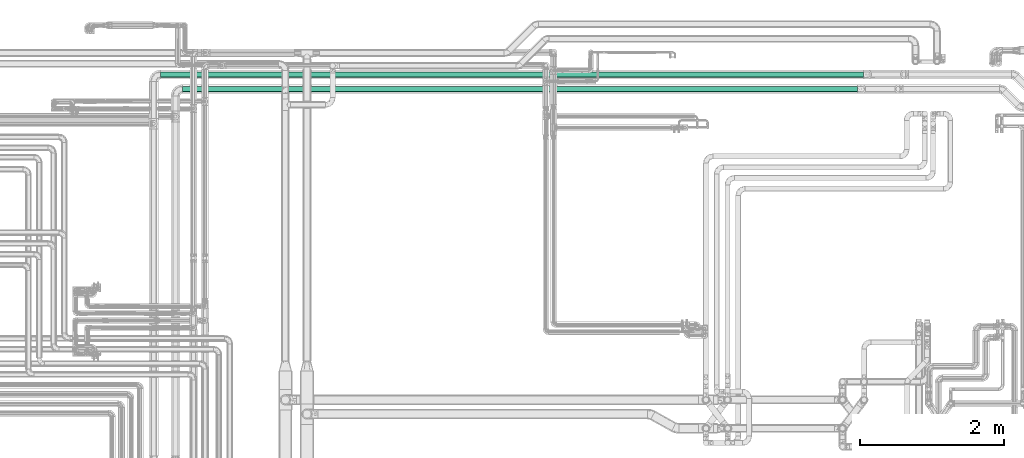
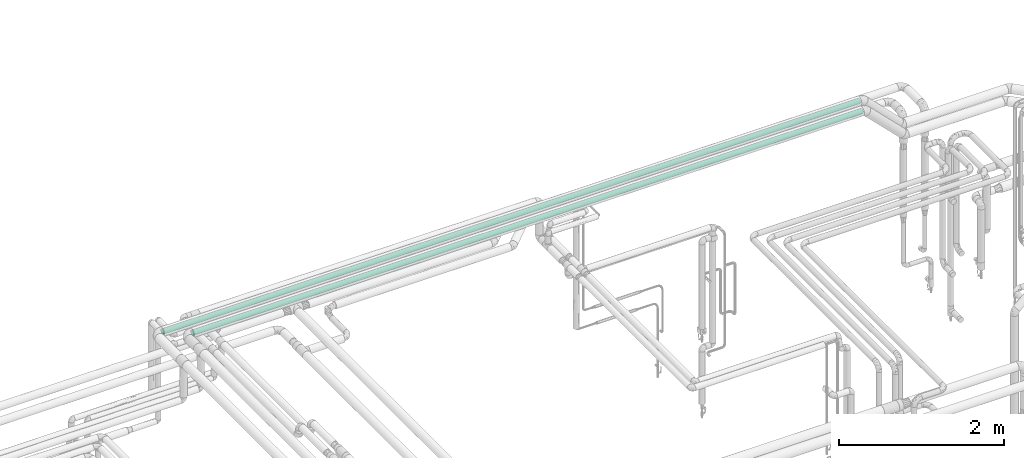
# One storey, part 537 of 827: 2 flow segments.
"""IFC2X3 building model written with IfcOpenShell, lengths in millimetres."""

from ifc_helpers import new_model, entity, si_unit, converted_unit, derived_unit, direction, frame, origin, origin_2d_with_axis, place, context, subcontext, project, spatial, circle, extrude, type_object, element, save


model = new_model("IFC2X3")

# Units and contexts
model_context = context("Model", 3, precision=0.01, world=origin(), true_north=direction((6.12303176911189e-17, 1.0)))
body_context = subcontext(model_context, "Body", "Model", "MODEL_VIEW")
ifc_project = project(units=[si_unit("LENGTHUNIT", "METRE", prefix="MILLI"), si_unit("AREAUNIT", "SQUARE_METRE"), si_unit("VOLUMEUNIT", "CUBIC_METRE"), converted_unit("PLANEANGLEUNIT", "DEGREE", entity("IfcRatioMeasure", 0.0174532925199433), si_unit("PLANEANGLEUNIT", "RADIAN"), dimensions=[0, 0, 0, 0, 0, 0, 0]), si_unit("MASSUNIT", "GRAM", prefix="KILO"), derived_unit("MASSDENSITYUNIT", [(si_unit("MASSUNIT", "GRAM", prefix="KILO"), 1), (si_unit("LENGTHUNIT", "METRE"), -3)]), derived_unit("MOMENTOFINERTIAUNIT", [(si_unit("LENGTHUNIT", "METRE"), 4)]), si_unit("TIMEUNIT", "SECOND"), si_unit("FREQUENCYUNIT", "HERTZ"), si_unit("THERMODYNAMICTEMPERATUREUNIT", "DEGREE_CELSIUS"), derived_unit("THERMALTRANSMITTANCEUNIT", [(si_unit("MASSUNIT", "GRAM", prefix="KILO"), 1), (si_unit("THERMODYNAMICTEMPERATUREUNIT", "KELVIN"), -1), (si_unit("TIMEUNIT", "SECOND"), -3)]), derived_unit("VOLUMETRICFLOWRATEUNIT", [(si_unit("LENGTHUNIT", "METRE"), 3), (si_unit("TIMEUNIT", "SECOND"), -1)]), derived_unit("MASSFLOWRATEUNIT", [(si_unit("MASSUNIT", "GRAM", prefix="KILO"), 1), (si_unit("TIMEUNIT", "SECOND"), -1)]), derived_unit("ROTATIONALFREQUENCYUNIT", [(si_unit("TIMEUNIT", "SECOND"), -1)]), si_unit("ELECTRICCURRENTUNIT", "AMPERE"), si_unit("ELECTRICVOLTAGEUNIT", "VOLT"), si_unit("POWERUNIT", "WATT"), si_unit("FORCEUNIT", "NEWTON", prefix="KILO"), si_unit("ILLUMINANCEUNIT", "LUX"), si_unit("LUMINOUSFLUXUNIT", "LUMEN"), si_unit("LUMINOUSINTENSITYUNIT", "CANDELA"), derived_unit("USERDEFINED", [(si_unit("MASSUNIT", "GRAM", prefix="KILO"), -1), (si_unit("LENGTHUNIT", "METRE"), -2), (si_unit("TIMEUNIT", "SECOND"), 3), (si_unit("LUMINOUSFLUXUNIT", "LUMEN"), 1)]), derived_unit("LINEARVELOCITYUNIT", [(si_unit("LENGTHUNIT", "METRE"), 1), (si_unit("TIMEUNIT", "SECOND"), -1)]), si_unit("PRESSUREUNIT", "PASCAL"), derived_unit("USERDEFINED", [(si_unit("LENGTHUNIT", "METRE"), -2), (si_unit("MASSUNIT", "GRAM", prefix="KILO"), 1), (si_unit("TIMEUNIT", "SECOND"), -2)]), derived_unit("LINEARFORCEUNIT", [(si_unit("MASSUNIT", "GRAM", prefix="KILO"), 1), (si_unit("LENGTHUNIT", "METRE"), 1), (si_unit("TIMEUNIT", "SECOND"), -2), (si_unit("LENGTHUNIT", "METRE"), -1)]), derived_unit("PLANARFORCEUNIT", [(si_unit("MASSUNIT", "GRAM", prefix="KILO"), 1), (si_unit("LENGTHUNIT", "METRE"), 1), (si_unit("TIMEUNIT", "SECOND"), -2), (si_unit("LENGTHUNIT", "METRE"), -2)])], contexts=[model_context])

# Site, building, storey
site_placement = place(None, origin())
site = spatial("IfcSite", under=ifc_project, at=site_placement, CompositionType="ELEMENT")
building_placement = place(site_placement, origin())
building = spatial("IfcBuilding", under=site, at=building_placement, CompositionType="ELEMENT")
storey_placement = place(building_placement, frame((0.0, 0.0, 28200.0)))
storey = spatial("IfcBuildingStorey", under=building, at=storey_placement, Name="08", CompositionType="ELEMENT", Elevation=28200.0)

# Flow segments
pipe_segment_type = type_object("IfcPipeSegmentType", PredefinedType="NOTDEFINED")
flow_segment_1_placement = place(storey_placement, frame((36012.93, 18769.53, 3510.65)))
element("IfcFlowSegment", 1, at=flow_segment_1_placement, inside=storey, type_object=pipe_segment_type, context=body_context, shape_type="SweptSolid", body=[
    extrude(circle(Radius=37.75, at=origin_2d_with_axis()), frame((0.0, 39.39, 39.35), z_axis=(1.0, -4.85826374194364e-06, 0.0), x_axis=(4.85826374194364e-06, 1.0, 0.0)), (0.0, 0.0, 1.0), 9771.53205023051),
])
flow_segment_2_placement = place(storey_placement, frame((36315.03, 18567.35, 3510.65)))
element("IfcFlowSegment", 2, at=flow_segment_2_placement, inside=storey, type_object=pipe_segment_type, context=body_context, shape_type="SweptSolid", body=[
    extrude(circle(Radius=37.75, at=origin_2d_with_axis()), frame((0.0, 39.35, 39.35), z_axis=(1.0, 0.0, 0.0), x_axis=(0.0, 1.0, 0.0)), (0.0, 0.0, 1.0), 9389.4356787662),
])

save(model, "model.ifc")
